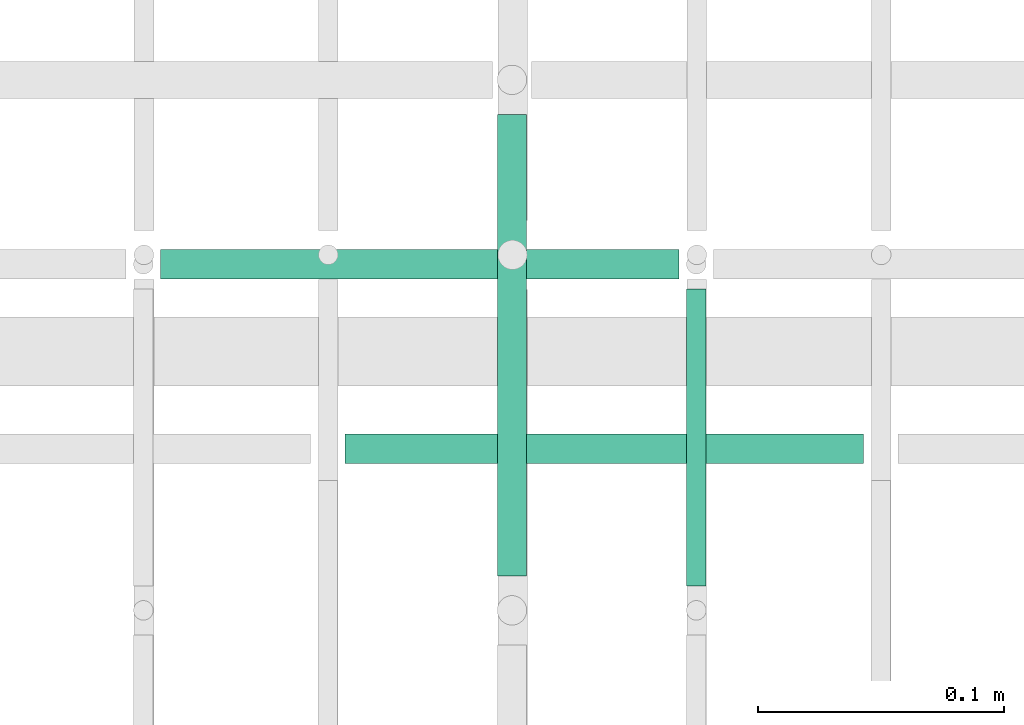
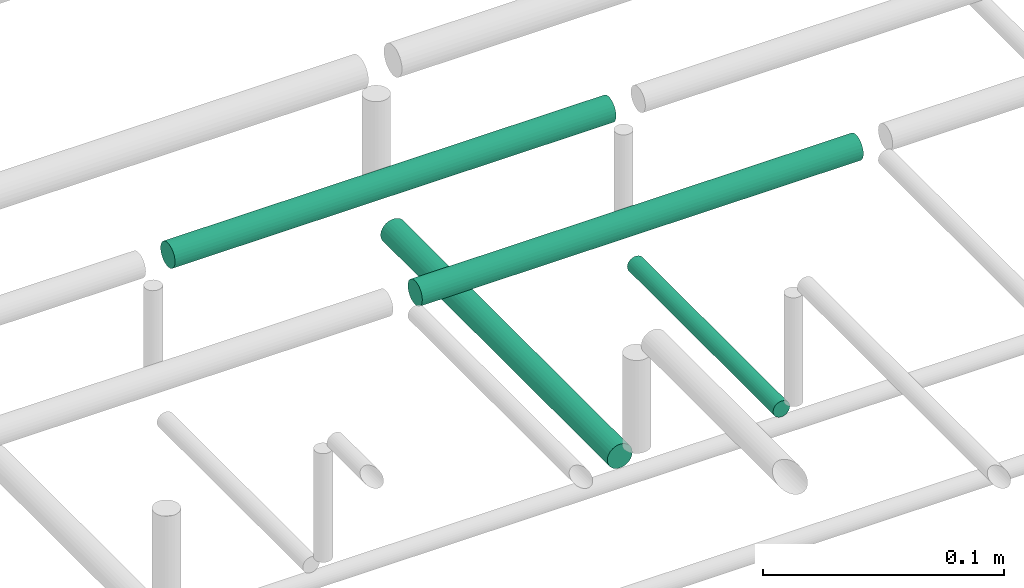
# One storey, part 155 of 331: 4 flow segments.
"""IFC2X3 building model written with IfcOpenShell, lengths in millimetres."""

from ifc_helpers import new_model, entity, si_unit, converted_unit, derived_unit, direction, frame, frame_2d, origin, origin_2d_with_axis, place, context, subcontext, project, spatial, circle, extrude, type_object, element, save


model = new_model("IFC2X3")

# Units and contexts
model_context = context("Model", 3, precision=0.01, world=origin(), true_north=direction((6.12303176911189e-17, 1.0)))
body_context = subcontext(model_context, "Body", "Model", "MODEL_VIEW")
ifc_project = project(units=[si_unit("LENGTHUNIT", "METRE", prefix="MILLI"), si_unit("AREAUNIT", "SQUARE_METRE"), si_unit("VOLUMEUNIT", "CUBIC_METRE"), converted_unit("PLANEANGLEUNIT", "DEGREE", entity("IfcRatioMeasure", 0.0174532925199433), si_unit("PLANEANGLEUNIT", "RADIAN"), dimensions=[0, 0, 0, 0, 0, 0, 0]), si_unit("MASSUNIT", "GRAM", prefix="KILO"), derived_unit("MASSDENSITYUNIT", [(si_unit("MASSUNIT", "GRAM", prefix="KILO"), 1), (si_unit("LENGTHUNIT", "METRE"), -3)]), derived_unit("MOMENTOFINERTIAUNIT", [(si_unit("LENGTHUNIT", "METRE"), 4)]), si_unit("TIMEUNIT", "SECOND"), si_unit("FREQUENCYUNIT", "HERTZ"), si_unit("THERMODYNAMICTEMPERATUREUNIT", "DEGREE_CELSIUS"), derived_unit("THERMALTRANSMITTANCEUNIT", [(si_unit("MASSUNIT", "GRAM", prefix="KILO"), 1), (si_unit("THERMODYNAMICTEMPERATUREUNIT", "KELVIN"), -1), (si_unit("TIMEUNIT", "SECOND"), -3)]), derived_unit("VOLUMETRICFLOWRATEUNIT", [(si_unit("LENGTHUNIT", "METRE"), 3), (si_unit("TIMEUNIT", "SECOND"), -1)]), derived_unit("MASSFLOWRATEUNIT", [(si_unit("MASSUNIT", "GRAM", prefix="KILO"), 1), (si_unit("TIMEUNIT", "SECOND"), -1)]), derived_unit("ROTATIONALFREQUENCYUNIT", [(si_unit("TIMEUNIT", "SECOND"), -1)]), si_unit("ELECTRICCURRENTUNIT", "AMPERE"), si_unit("ELECTRICVOLTAGEUNIT", "VOLT"), si_unit("POWERUNIT", "WATT"), si_unit("FORCEUNIT", "NEWTON", prefix="KILO"), si_unit("ILLUMINANCEUNIT", "LUX"), si_unit("LUMINOUSFLUXUNIT", "LUMEN"), si_unit("LUMINOUSINTENSITYUNIT", "CANDELA"), derived_unit("USERDEFINED", [(si_unit("MASSUNIT", "GRAM", prefix="KILO"), -1), (si_unit("LENGTHUNIT", "METRE"), -2), (si_unit("TIMEUNIT", "SECOND"), 3), (si_unit("LUMINOUSFLUXUNIT", "LUMEN"), 1)]), derived_unit("LINEARVELOCITYUNIT", [(si_unit("LENGTHUNIT", "METRE"), 1), (si_unit("TIMEUNIT", "SECOND"), -1)]), si_unit("PRESSUREUNIT", "PASCAL"), derived_unit("USERDEFINED", [(si_unit("LENGTHUNIT", "METRE"), -2), (si_unit("MASSUNIT", "GRAM", prefix="KILO"), 1), (si_unit("TIMEUNIT", "SECOND"), -2)]), derived_unit("LINEARFORCEUNIT", [(si_unit("MASSUNIT", "GRAM", prefix="KILO"), 1), (si_unit("LENGTHUNIT", "METRE"), 1), (si_unit("TIMEUNIT", "SECOND"), -2), (si_unit("LENGTHUNIT", "METRE"), -1)]), derived_unit("PLANARFORCEUNIT", [(si_unit("MASSUNIT", "GRAM", prefix="KILO"), 1), (si_unit("LENGTHUNIT", "METRE"), 1), (si_unit("TIMEUNIT", "SECOND"), -2), (si_unit("LENGTHUNIT", "METRE"), -2)])], contexts=[model_context])

# Site, building, storey
site_placement = place(None, frame((0.0, -0.00077364408347762, 0.0)))
site = spatial("IfcSite", under=ifc_project, at=site_placement, CompositionType="ELEMENT")
building_placement = place(site_placement, origin())
building = spatial("IfcBuilding", under=site, at=building_placement, CompositionType="ELEMENT")
storey_placement = place(building_placement, origin())
storey = spatial("IfcBuildingStorey", under=building, at=storey_placement, CompositionType="ELEMENT", Elevation=0.0)

# Flow segments
pipe_segment_type = type_object("IfcPipeSegmentType", PredefinedType="NOTDEFINED")
flow_segment_1_placement = place(storey_placement, frame((35690.5130615671, 8100.14924977613, 14669.4047277641)))
element("IfcFlowSegment", 1, at=flow_segment_1_placement, inside=storey, type_object=pipe_segment_type, context=body_context, shape_type="SweptSolid", body=[
    extrude(circle(Radius=4.0, at=origin_2d_with_axis()), frame((5.59527223591499, 0.0, 5.59527223591499), z_axis=(0.0, 1.0, 0.0), x_axis=(1.0, 0.0, 0.0)), (0.0, 0.0, 1.0), 120.860694073194),
])
flow_segment_2_placement = place(storey_placement, frame((35613.5130615671, 8104.14924977613, 14667.4047277641)))
element("IfcFlowSegment", 2, at=flow_segment_2_placement, inside=storey, type_object=pipe_segment_type, context=body_context, shape_type="SweptSolid", body=[
    extrude(circle(Radius=6.0, at=frame_2d((0.0, 2.16573425859679e-12), x_axis=(1.0, 0.0))), frame((7.59527223591454, 0.0, 7.59527223591887), z_axis=(0.0, 1.0, 0.0), x_axis=(1.0, 0.0, 0.0)), (0.0, 0.0, 1.0), 187.860694073193),
])
flow_segment_3_placement = place(storey_placement, frame((35553.108333803, 8148.41467161338, 14742.4047277641)))
element("IfcFlowSegment", 3, at=flow_segment_3_placement, inside=storey, type_object=pipe_segment_type, context=body_context, shape_type="SweptSolid", body=[
    extrude(circle(Radius=6.0, at=origin_2d_with_axis()), frame((0.0, 7.59527223591562, 7.59527223591454), z_axis=(1.0, 0.0, 0.0), x_axis=(0.0, 1.0, 0.0)), (0.0, 0.0, 1.0), 211.0),
])
flow_segment_4_placement = place(storey_placement, frame((35478.108346438, 8223.41467161341, 14742.4047283741)))
element("IfcFlowSegment", 4, at=flow_segment_4_placement, inside=storey, type_object=pipe_segment_type, context=body_context, shape_type="SweptSolid", body=[
    extrude(circle(Radius=6.0, at=origin_2d_with_axis()), frame((0.0, 7.59527223591562, 7.5952722359167), z_axis=(1.0, 0.0, 0.0), x_axis=(0.0, 1.0, 0.0)), (0.0, 0.0, 1.0), 210.999991286194),
])

save(model, "model.ifc")
